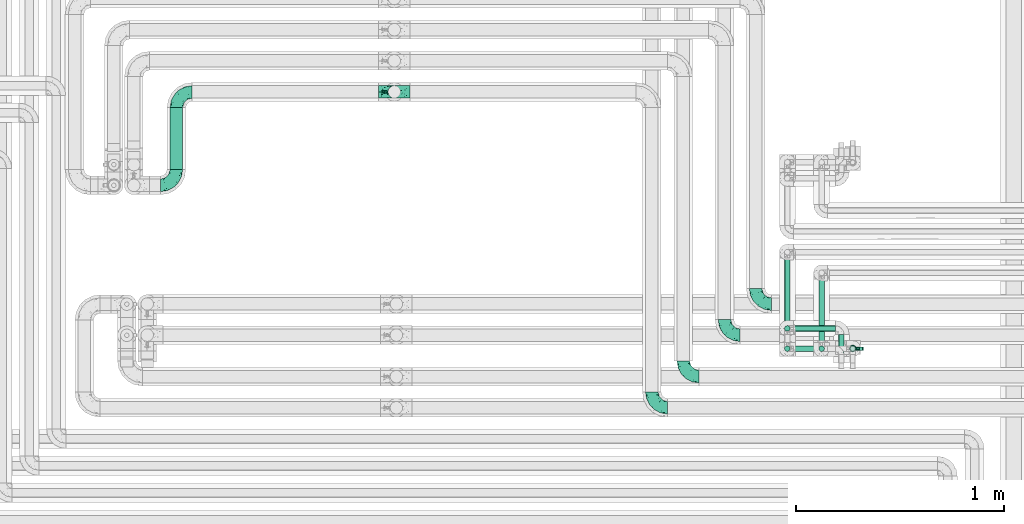
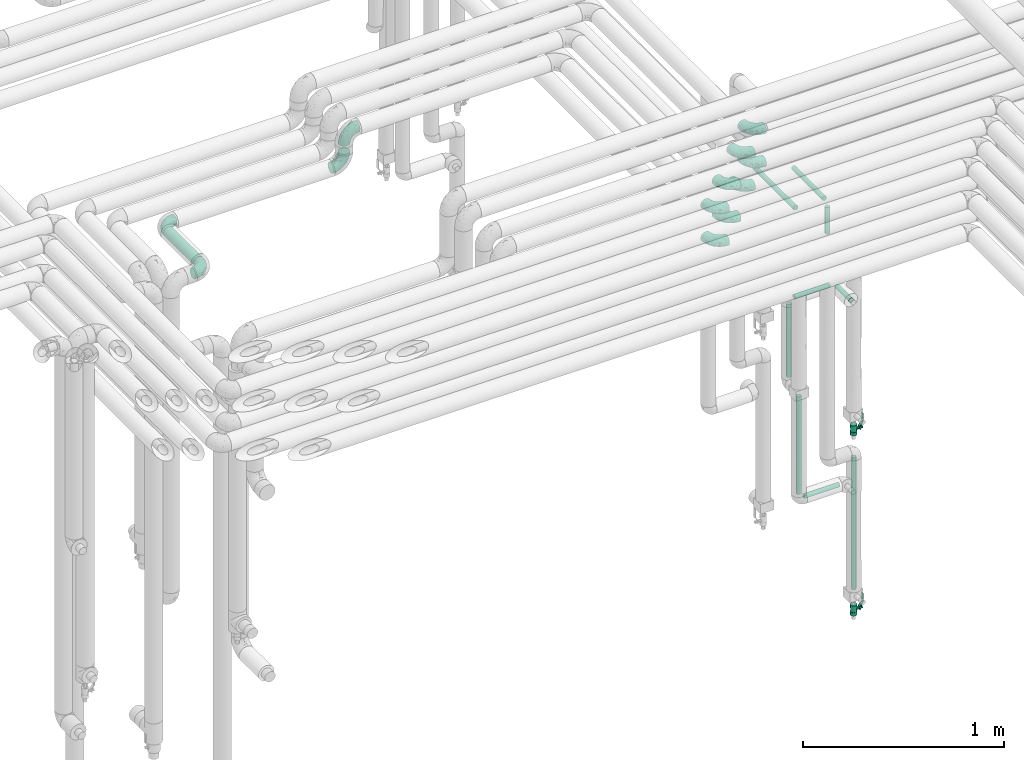
# One storey, part 634 of 824: 12 flow fittings, 10 flow segments, 2 flow controllers.
"""IFC2X3 building model written with IfcOpenShell, lengths in millimetres."""

from ifc_helpers import new_model, entity, si_unit, converted_unit, derived_unit, direction, frame, origin, origin_2d_with_axis, place, context, subcontext, project, spatial, polyline, circle, outline, extrude, faceted_brep, source, transform, mapped, material, material_list, type_object, type_shapes, element, save


model = new_model("IFC2X3")

# Units and contexts
model_context = context("Model", 3, precision=0.01, world=origin(), true_north=direction((6.12303176911189e-17, 1.0)))
body_context = subcontext(model_context, "Body", "Model", "MODEL_VIEW")
ifc_project = project(units=[si_unit("LENGTHUNIT", "METRE", prefix="MILLI"), si_unit("AREAUNIT", "SQUARE_METRE"), si_unit("VOLUMEUNIT", "CUBIC_METRE"), converted_unit("PLANEANGLEUNIT", "DEGREE", entity("IfcRatioMeasure", 0.0174532925199433), si_unit("PLANEANGLEUNIT", "RADIAN"), dimensions=[0, 0, 0, 0, 0, 0, 0]), si_unit("MASSUNIT", "GRAM", prefix="KILO"), derived_unit("MASSDENSITYUNIT", [(si_unit("MASSUNIT", "GRAM", prefix="KILO"), 1), (si_unit("LENGTHUNIT", "METRE"), -3)]), derived_unit("MOMENTOFINERTIAUNIT", [(si_unit("LENGTHUNIT", "METRE"), 4)]), si_unit("TIMEUNIT", "SECOND"), si_unit("FREQUENCYUNIT", "HERTZ"), si_unit("THERMODYNAMICTEMPERATUREUNIT", "DEGREE_CELSIUS"), derived_unit("THERMALTRANSMITTANCEUNIT", [(si_unit("MASSUNIT", "GRAM", prefix="KILO"), 1), (si_unit("THERMODYNAMICTEMPERATUREUNIT", "KELVIN"), -1), (si_unit("TIMEUNIT", "SECOND"), -3)]), derived_unit("VOLUMETRICFLOWRATEUNIT", [(si_unit("LENGTHUNIT", "METRE"), 3), (si_unit("TIMEUNIT", "SECOND"), -1)]), derived_unit("MASSFLOWRATEUNIT", [(si_unit("MASSUNIT", "GRAM", prefix="KILO"), 1), (si_unit("TIMEUNIT", "SECOND"), -1)]), derived_unit("ROTATIONALFREQUENCYUNIT", [(si_unit("TIMEUNIT", "SECOND"), -1)]), si_unit("ELECTRICCURRENTUNIT", "AMPERE"), si_unit("ELECTRICVOLTAGEUNIT", "VOLT"), si_unit("POWERUNIT", "WATT"), si_unit("FORCEUNIT", "NEWTON", prefix="KILO"), si_unit("ILLUMINANCEUNIT", "LUX"), si_unit("LUMINOUSFLUXUNIT", "LUMEN"), si_unit("LUMINOUSINTENSITYUNIT", "CANDELA"), derived_unit("USERDEFINED", [(si_unit("MASSUNIT", "GRAM", prefix="KILO"), -1), (si_unit("LENGTHUNIT", "METRE"), -2), (si_unit("TIMEUNIT", "SECOND"), 3), (si_unit("LUMINOUSFLUXUNIT", "LUMEN"), 1)]), derived_unit("LINEARVELOCITYUNIT", [(si_unit("LENGTHUNIT", "METRE"), 1), (si_unit("TIMEUNIT", "SECOND"), -1)]), si_unit("PRESSUREUNIT", "PASCAL"), derived_unit("USERDEFINED", [(si_unit("LENGTHUNIT", "METRE"), -2), (si_unit("MASSUNIT", "GRAM", prefix="KILO"), 1), (si_unit("TIMEUNIT", "SECOND"), -2)]), derived_unit("LINEARFORCEUNIT", [(si_unit("MASSUNIT", "GRAM", prefix="KILO"), 1), (si_unit("LENGTHUNIT", "METRE"), 1), (si_unit("TIMEUNIT", "SECOND"), -2), (si_unit("LENGTHUNIT", "METRE"), -1)]), derived_unit("PLANARFORCEUNIT", [(si_unit("MASSUNIT", "GRAM", prefix="KILO"), 1), (si_unit("LENGTHUNIT", "METRE"), 1), (si_unit("TIMEUNIT", "SECOND"), -2), (si_unit("LENGTHUNIT", "METRE"), -2)])], contexts=[model_context])

# Site, building, storey
site_placement = place(None, origin())
site = spatial("IfcSite", under=ifc_project, at=site_placement, CompositionType="ELEMENT")
building_placement = place(site_placement, origin())
building = spatial("IfcBuilding", under=site, at=building_placement, CompositionType="ELEMENT")
storey_placement = place(building_placement, frame((0.0, 0.0, 28200.0)))
storey = spatial("IfcBuildingStorey", under=building, at=storey_placement, CompositionType="ELEMENT", Elevation=28200.0)

# Flow segments
pipe_segment_type = type_object("IfcPipeSegmentType", PredefinedType="NOTDEFINED")
flow_segment_1_placement = place(storey_placement, frame((31853.66, 15787.2, 2968.4)))
element("IfcFlowSegment", 1, at=flow_segment_1_placement, inside=storey, type_object=pipe_segment_type, context=body_context, shape_type="SweptSolid", body=[
    extrude(circle(Radius=30.0, at=origin_2d_with_axis()), frame((31.6, 0.0, 31.6), z_axis=(0.0, 1.0, 0.0), x_axis=(-1.0, 0.0, 0.0)), (0.0, 0.0, 1.0), 298.000000000006),
])
flow_segment_2_placement = place(storey_placement, frame((34812.85, 14909.92, 1089.1)))
element("IfcFlowSegment", 2, at=flow_segment_2_placement, inside=storey, type_object=pipe_segment_type, context=body_context, shape_type="SweptSolid", body=[
    extrude(circle(Radius=13.4, at=origin_2d_with_axis()), frame((15.0, 15.0, 0.0)), (0.0, 0.0, 1.0), 591.900000000008),
])
flow_segment_3_placement = place(storey_placement, frame((34856.95, 14909.92, 1045.0)))
element("IfcFlowSegment", 3, at=flow_segment_3_placement, inside=storey, type_object=pipe_segment_type, context=body_context, shape_type="SweptSolid", body=[
    extrude(circle(Radius=13.4, at=origin_2d_with_axis()), frame((0.0, 15.0, 15.0), z_axis=(1.0, 0.0, 0.0), x_axis=(0.0, -1.0, 0.0)), (0.0, 0.0, 1.0), 201.799999999997),
])
flow_segment_4_placement = place(storey_placement, frame((34856.95, 15006.91, 2195.0)))
element("IfcFlowSegment", 4, at=flow_segment_4_placement, inside=storey, type_object=pipe_segment_type, context=body_context, shape_type="SweptSolid", body=[
    extrude(circle(Radius=13.4, at=origin_2d_with_axis()), frame((0.0, 15.0, 15.0), z_axis=(1.0, 0.0, 0.0), x_axis=(0.0, 1.0, 0.0)), (0.0, 0.0, 1.0), 201.799999999997),
])
flow_segment_5_placement = place(storey_placement, frame((35072.85, 14854.91, 2195.0)))
element("IfcFlowSegment", 5, at=flow_segment_5_placement, inside=storey, type_object=pipe_segment_type, context=body_context, shape_type="SweptSolid", body=[
    extrude(circle(Radius=13.4, at=origin_2d_with_axis()), frame((15.0, 0.0, 15.0), z_axis=(0.0, 1.0, 0.0), x_axis=(1.0, 0.0, 0.0)), (0.0, 0.0, 1.0), 137.895089895177),
])
flow_segment_6_placement = place(storey_placement, frame((34812.85, 15006.91, 1739.1)))
element("IfcFlowSegment", 6, at=flow_segment_6_placement, inside=storey, type_object=pipe_segment_type, context=body_context, shape_type="SweptSolid", body=[
    extrude(circle(Radius=13.4, at=origin_2d_with_axis()), frame((15.0, 15.0, 0.0)), (0.0, 0.0, 1.0), 441.800000000021),
])
flow_segment_7_placement = place(storey_placement, frame((35127.89, 14909.92, 401.0)))
element("IfcFlowSegment", 7, at=flow_segment_7_placement, inside=storey, type_object=pipe_segment_type, context=body_context, shape_type="SweptSolid", body=[
    extrude(circle(Radius=13.4, at=origin_2d_with_axis()), frame((15.0, 15.0, 0.0)), (0.0, 0.0, 1.0), 799.899999999658),
])
flow_segment_8_placement = place(storey_placement, frame((34977.89, 14909.92, 2609.0)))
element("IfcFlowSegment", 8, at=flow_segment_8_placement, inside=storey, type_object=pipe_segment_type, context=body_context, shape_type="SweptSolid", body=[
    extrude(circle(Radius=13.4, at=origin_2d_with_axis()), frame((15.0, 15.0, 0.0), z_axis=(0.0, 0.0, 1.0), x_axis=(-1.0, 0.0, 0.0)), (0.0, 0.0, 1.0), 161.899999999968),
])
flow_segment_9_placement = place(storey_placement, frame((34977.89, 14954.01, 2785.0)))
element("IfcFlowSegment", 9, at=flow_segment_9_placement, inside=storey, type_object=pipe_segment_type, context=body_context, shape_type="SweptSolid", body=[
    extrude(circle(Radius=13.4, at=origin_2d_with_axis()), frame((15.0, 0.0, 15.0), z_axis=(0.0, 1.0, 0.0), x_axis=(-1.0, 0.0, 0.0)), (0.0, 0.0, 1.0), 306.888117846957),
])
flow_segment_10_placement = place(storey_placement, frame((34812.85, 14954.01, 2785.0)))
element("IfcFlowSegment", 10, at=flow_segment_10_placement, inside=storey, type_object=pipe_segment_type, context=body_context, shape_type="SweptSolid", body=[
    extrude(circle(Radius=13.4, at=origin_2d_with_axis()), frame((15.0, 0.0, 15.0), z_axis=(0.0, 1.0, 0.0), x_axis=(1.0, 0.0, 0.0)), (0.0, 0.0, 1.0), 406.488125846979),
])

# Flow controllers
ifc_material = material()
ifc_material_list = material_list([ifc_material, ifc_material, ifc_material, ifc_material, ifc_material])
valve_type = type_object("IfcValveType", PredefinedType="NOTDEFINED", material=ifc_material_list)
shared_shape_1 = source(origin(), body_context, "Body", "SweptSolid", [
    extrude(circle(Radius=17.5, at=origin_2d_with_axis()), frame((-30.5, 0.0, 0.0), z_axis=(1.0, 0.0, 0.0), x_axis=(0.0, 1.0, 0.0)), (0.0, 0.0, 1.0), 20.3333333333333),
    extrude(circle(Radius=16.0, at=origin_2d_with_axis()), frame((-10.17, 0.0, 0.0), z_axis=(1.0, 0.0, 0.0), x_axis=(0.0, 1.0, 0.0)), (0.0, 0.0, 1.0), 20.3333333333333),
    extrude(circle(Radius=17.5, at=origin_2d_with_axis()), frame((10.17, 0.0, 0.0), z_axis=(1.0, 0.0, 0.0), x_axis=(0.0, 1.0, 0.0)), (0.0, 0.0, 1.0), 20.3333333333333),
    extrude(outline(polyline([(-38.75, -5.0), (-38.75, -10.0), (-17.92, -10.0), (2.08, 5.0), (56.25, 5.0), (56.25, 10.0), (0.42, 10.0), (-19.58, -5.0), (-38.75, -5.0)])), frame((28.75, -8.75, 41.5), z_axis=(0.0, -1.0, 0.0), x_axis=(1.0, 0.0, 0.0)), (0.0, 0.0, -1.0), 17.5),
    extrude(circle(Radius=8.0, at=origin_2d_with_axis()), origin(), (0.0, 0.0, 1.0), 49.0),
])
type_shapes(valve_type, [shared_shape_1])
for number, where, z_axis, x_axis in (
    (11, (35142.88, 14924.91, 274.5), (1.0, 0.0, 0.0), (0.0, 0.0, 1.0)),
    (12, (35142.88, 14924.91, 1366.0), (1.0, 0.0, 0.0), (0.0, 0.0, 1.0)),
):
    element("IfcFlowController", number, at=place(storey_placement, frame(where, z_axis=z_axis, x_axis=x_axis)), inside=storey, type_object=valve_type, material=ifc_material, context=body_context, shape_type="MappedRepresentation", body=[
        mapped(shared_shape_1, transform((0.0, 0.0, 0.0), scale=1.0)),
    ])

# Flow fittings
pipe_fitting_type = type_object("IfcPipeFittingType", PredefinedType="NOTDEFINED", material=ifc_material)
shared_shape_2 = source(origin(), body_context, "Body", "Brep", [
    faceted_brep([(-76.0, 15.07, -26.11), (-76.0, 7.8, -29.12), (-76.0, 0.0, -30.15), (-76.0, -7.8, -29.12), (-76.0, -15.08, -26.11), (-76.0, -21.32, -21.32), (-76.0, -26.11, -15.08), (-76.0, -29.12, -7.8), (-76.0, -30.15, 0.0), (-76.0, -29.12, 7.8), (-76.0, -26.11, 15.07), (-76.0, -21.32, 21.32), (-76.0, -15.08, 26.11), (-76.0, -7.8, 29.12), (-76.0, 0.0, 30.15), (-76.0, 7.8, 29.12), (-76.0, 15.07, 26.11), (-76.0, 21.32, 21.32), (-76.0, 26.11, 15.07), (-76.0, 29.12, 7.8), (-76.0, 30.15, 0.0), (-76.0, 29.12, -7.8), (-76.0, 26.11, -15.08), (-76.0, 21.32, -21.32), (0.0, 76.0, -30.15), (-7.8, 76.0, -29.12), (-15.07, 76.0, -26.11), (-21.32, 76.0, -21.32), (-26.11, 76.0, -15.08), (-29.12, 76.0, -7.8), (-30.15, 76.0, 0.0), (-29.12, 76.0, 7.8), (-26.11, 76.0, 15.07), (-21.32, 76.0, 21.32), (-15.07, 76.0, 26.11), (-7.8, 76.0, 29.12), (0.0, 76.0, 30.15), (7.8, 76.0, 29.12), (15.08, 76.0, 26.11), (21.32, 76.0, 21.32), (26.11, 76.0, 15.07), (29.12, 76.0, 7.8), (30.15, 76.0, 0.0), (29.12, 76.0, -7.8), (26.11, 76.0, -15.08), (21.32, 76.0, -21.32), (15.08, 76.0, -26.11), (7.8, 76.0, -29.12), (10.79, 31.43, 21.07), (4.32, 31.7, 25.72), (1.65, 15.19, 19.92), (-61.17, -27.8, 0.0), (-51.1, -25.49, 9.84), (-56.14, -10.61, 27.27), (-31.7, -4.32, 25.72), (-39.75, 1.72, 29.41), (-43.2, -24.95, 0.0), (-1.86, 1.86, 0.0), (4.49, 7.65, 5.78), (-7.82, -4.61, 5.83), (-56.21, -22.79, 17.21), (-58.98, -3.38, 29.7), (-53.96, 5.6, 30.07), (-10.86, 10.86, 25.48), (-17.2, -2.6, 20.44), (-49.15, -16.01, 22.7), (-22.18, -14.24, 7.99), (-28.4, -17.42, 0.0), (-13.61, -9.88, 0.0), (-39.0, 23.48, 27.76), (-58.76, 12.54, 28.36), (-41.61, 15.41, 29.48), (16.01, 49.15, 22.7), (-58.55, 25.93, 19.53), (-51.53, 33.5, 13.51), (-64.92, 28.76, 12.4), (-7.48, 23.14, 28.25), (-1.72, 39.75, 29.41), (-12.04, 27.88, 29.88), (-63.91, 18.81, 24.52), (-11.63, 65.16, 28.18), (-4.97, 57.02, 30.05), (9.88, 13.61, 0.0), (-62.5, 31.74, 5.02), (-45.17, 30.98, 21.2), (-21.78, 9.76, 28.58), (10.61, 56.14, 27.27), (-32.09, 54.42, 13.26), (22.79, 56.21, 17.21), (15.38, 31.17, 15.63), (25.49, 51.1, 9.84), (21.84, 36.35, 5.92), (24.95, 43.2, 0.0), (3.38, 58.98, 29.7), (-31.17, -15.38, 15.63), (-39.39, 41.78, 15.45), (-34.56, 41.13, 20.79), (-39.81, -23.25, 5.49), (27.8, 61.17, 0.0), (-31.74, 62.5, 5.02), (-53.07, 36.29, 0.0), (-42.95, 42.95, 7.29), (-36.29, 53.07, 0.0), (-19.83, 58.51, 24.79), (-25.48, 60.2, 19.41), (-14.53, 50.96, 28.57), (-13.31, 37.09, 30.07), (-26.16, 40.06, 26.4), (-32.43, -10.35, 21.9), (17.42, 28.4, 0.0), (14.24, 22.18, 7.99), (-38.67, 9.72, 30.15), (-24.66, 17.36, 30.09), (-37.08, 31.49, 24.99), (-49.27, 22.83, 25.24), (-20.8, 38.81, 28.63), (-27.58, 27.58, 29.2), (-36.07, -20.23, 10.71), (-15.19, -6.16, 14.9), (6.6, 15.4, 14.49), (-2.51, 2.51, 11.35), (-65.16, 11.63, -28.18), (-49.15, -16.01, -22.7), (-57.02, 4.97, -30.05), (-25.93, 58.55, -19.53), (-33.5, 51.53, -13.51), (-28.76, 64.92, -12.4), (-60.2, 25.48, -19.41), (-58.51, 19.83, -24.79), (4.61, 7.82, -5.83), (-7.65, -4.49, -5.78), (-2.51, 2.51, -11.35), (-62.5, 31.74, -5.02), (-50.96, 14.53, -28.57), (-37.09, 13.31, -30.07), (-42.95, 42.95, -7.29), (25.49, 51.1, -9.84), (22.79, 56.21, -17.21), (-40.06, 26.16, -26.4), (3.38, 58.98, -29.7), (-5.6, 53.96, -30.07), (-27.88, 12.04, -29.88), (-9.76, 21.78, -28.58), (-23.14, 7.48, -28.25), (-51.1, -25.49, -9.84), (15.38, 31.17, -15.63), (16.01, 49.15, -22.7), (-23.48, 39.0, -27.76), (-12.54, 58.76, -28.36), (-15.41, 41.61, -29.48), (-56.21, -22.79, -17.21), (-9.72, 38.67, -30.15), (-17.36, 24.66, -30.09), (-22.18, -14.24, -7.99), (-41.13, 34.56, -20.79), (-31.74, 62.5, -5.02), (-58.98, -3.38, -29.7), (-31.17, -15.38, -15.63), (-56.14, -10.61, -27.27), (14.24, 22.18, -7.99), (23.25, 39.81, -5.49), (-31.49, 37.08, -24.99), (-15.19, -6.16, -14.9), (1.65, 15.19, -19.92), (-18.81, 63.91, -24.52), (-32.59, -11.62, -20.84), (-31.7, -4.32, -25.72), (-17.2, -2.6, -20.44), (-39.75, 1.72, -29.41), (-54.42, 32.09, -13.26), (-30.98, 45.17, -21.2), (10.61, 56.14, -27.27), (10.23, 31.31, -21.52), (4.32, 31.7, -25.72), (-41.78, 39.39, -15.45), (-1.72, 39.75, -29.41), (-36.35, -21.84, -5.92), (-22.83, 49.27, -25.24), (-38.81, 20.8, -28.63), (-27.58, 27.58, -29.2), (-10.86, 10.86, -25.48), (20.23, 36.07, -10.71), (6.6, 15.4, -14.49)], [[[0, 1, 2, 3, 4, 5, 6, 7, 8, 9, 10, 11, 12, 13, 14, 15, 16, 17, 18, 19, 20, 21, 22, 23]], [[24, 25, 26, 27, 28, 29, 30, 31, 32, 33, 34, 35, 36, 37, 38, 39, 40, 41, 42, 43, 44, 45, 46, 47]], [[48, 49, 50]], [[51, 52, 9]], [[53, 54, 55]], [[9, 52, 10]], [[56, 52, 51]], [[57, 58, 59]], [[11, 10, 60]], [[14, 61, 62]], [[63, 54, 64]], [[65, 12, 11]], [[65, 53, 12]], [[66, 67, 68]], [[69, 70, 71]], [[72, 39, 38]], [[73, 74, 75]], [[15, 70, 16]], [[76, 77, 78]], [[16, 79, 17]], [[13, 61, 14]], [[35, 80, 81]], [[14, 62, 15]], [[17, 73, 18]], [[57, 82, 58]], [[20, 19, 83]], [[75, 19, 18]], [[70, 15, 62]], [[73, 84, 74]], [[78, 85, 76]], [[38, 86, 72]], [[32, 31, 87]], [[88, 89, 90]], [[91, 92, 90]], [[72, 86, 49]], [[36, 93, 37]], [[75, 83, 19]], [[36, 35, 81]], [[60, 94, 65]], [[40, 90, 41]], [[95, 96, 87]], [[88, 90, 40]], [[66, 97, 67]], [[90, 98, 41]], [[40, 39, 88]], [[99, 31, 30]], [[20, 83, 100]], [[101, 102, 100]], [[52, 60, 10]], [[102, 99, 30]], [[96, 103, 104]], [[83, 101, 100]], [[12, 53, 13]], [[104, 103, 33]], [[105, 106, 81]], [[107, 105, 103]], [[64, 54, 108]], [[80, 103, 105]], [[80, 35, 34]], [[34, 33, 103]], [[86, 38, 37]], [[109, 110, 82]], [[71, 111, 112]], [[69, 107, 113]], [[79, 73, 17]], [[114, 113, 84]], [[33, 32, 104]], [[115, 107, 116]], [[105, 115, 106]], [[93, 81, 77]], [[54, 53, 65]], [[61, 53, 55]], [[108, 94, 64]], [[54, 63, 85]], [[93, 86, 37]], [[77, 76, 49]], [[77, 49, 86]], [[49, 63, 50]], [[60, 52, 117]], [[65, 11, 60]], [[39, 72, 88]], [[89, 88, 72]], [[71, 70, 62]], [[79, 70, 114]], [[103, 96, 107]], [[69, 113, 114]], [[112, 106, 116]], [[77, 81, 106]], [[112, 116, 71]], [[112, 55, 85]], [[64, 50, 63]], [[57, 59, 68]], [[32, 87, 104]], [[96, 104, 87]], [[94, 118, 64]], [[50, 119, 89]], [[50, 64, 118]], [[50, 89, 48]], [[81, 93, 36]], [[86, 93, 77]], [[53, 61, 13]], [[62, 61, 55]], [[71, 62, 111]], [[69, 71, 116]], [[95, 101, 74]], [[99, 101, 87]], [[118, 66, 59]], [[117, 97, 66]], [[117, 66, 94]], [[91, 89, 110]], [[91, 110, 109]], [[110, 89, 119]], [[9, 8, 51]], [[98, 90, 92]], [[98, 42, 41]], [[101, 83, 74]], [[101, 99, 102]], [[87, 31, 99]], [[62, 55, 111]], [[55, 112, 111]], [[107, 69, 116]], [[70, 69, 114]], [[107, 96, 113]], [[84, 113, 96]], [[84, 96, 95]], [[114, 84, 73]], [[70, 79, 16]], [[73, 79, 114]], [[54, 85, 55]], [[76, 85, 63]], [[49, 76, 63]], [[77, 106, 78]], [[106, 112, 78]], [[85, 78, 112]], [[73, 75, 18]], [[83, 75, 74]], [[103, 80, 34]], [[81, 80, 105]], [[101, 95, 87]], [[84, 95, 74]], [[106, 115, 116]], [[105, 107, 115]], [[120, 59, 58]], [[82, 110, 58]], [[119, 58, 110]], [[118, 59, 120]], [[66, 68, 59]], [[54, 65, 108]], [[94, 108, 65]], [[66, 118, 94]], [[50, 118, 120]], [[50, 120, 119]], [[119, 120, 58]], [[89, 72, 48]], [[49, 48, 72]], [[60, 117, 94]], [[117, 52, 97]], [[52, 56, 97]], [[67, 97, 56]], [[92, 91, 109]], [[89, 91, 90]], [[121, 1, 0]], [[122, 5, 4]], [[2, 1, 123]], [[124, 125, 126]], [[127, 128, 23]], [[129, 130, 131]], [[100, 132, 20]], [[133, 134, 123]], [[135, 100, 102]], [[136, 137, 44]], [[133, 128, 138]], [[24, 139, 140]], [[141, 142, 143]], [[121, 128, 133]], [[6, 144, 7]], [[137, 145, 146]], [[144, 51, 7]], [[147, 148, 149]], [[144, 6, 150]], [[149, 151, 152]], [[153, 68, 67]], [[154, 128, 127]], [[30, 155, 102]], [[43, 42, 98]], [[156, 3, 2]], [[157, 144, 150]], [[158, 4, 3]], [[24, 140, 25]], [[155, 135, 102]], [[159, 160, 109]], [[30, 29, 155]], [[147, 138, 161]], [[27, 124, 28]], [[57, 129, 82]], [[162, 163, 131]], [[27, 26, 164]], [[148, 26, 25]], [[165, 166, 167]], [[24, 47, 139]], [[143, 168, 141]], [[22, 21, 169]], [[125, 124, 170]], [[148, 25, 140]], [[46, 146, 171]], [[158, 122, 4]], [[0, 23, 128]], [[1, 121, 123]], [[109, 82, 159]], [[45, 44, 137]], [[146, 46, 45]], [[136, 43, 98]], [[132, 21, 20]], [[136, 98, 92]], [[172, 173, 146]], [[46, 171, 47]], [[43, 136, 44]], [[174, 154, 169]], [[171, 173, 175]], [[6, 5, 150]], [[126, 29, 28]], [[176, 56, 144]], [[122, 158, 166]], [[164, 124, 27]], [[177, 161, 170]], [[23, 22, 127]], [[178, 138, 179]], [[133, 178, 134]], [[156, 123, 168]], [[156, 158, 3]], [[168, 143, 166]], [[168, 166, 158]], [[166, 180, 167]], [[173, 171, 146]], [[139, 171, 175]], [[172, 145, 163]], [[173, 180, 142]], [[5, 122, 150]], [[157, 150, 122]], [[137, 136, 181]], [[146, 45, 137]], [[149, 148, 140]], [[164, 148, 177]], [[128, 154, 138]], [[147, 161, 177]], [[152, 134, 179]], [[168, 123, 134]], [[152, 179, 149]], [[152, 175, 142]], [[57, 130, 129]], [[157, 165, 167]], [[22, 169, 127]], [[154, 127, 169]], [[163, 167, 180]], [[162, 157, 167]], [[173, 163, 180]], [[182, 163, 145]], [[123, 156, 2]], [[158, 156, 168]], [[171, 139, 47]], [[140, 139, 175]], [[149, 140, 151]], [[147, 149, 179]], [[174, 135, 125]], [[132, 135, 169]], [[176, 157, 153]], [[176, 153, 67]], [[153, 157, 162]], [[182, 159, 129]], [[181, 160, 159]], [[181, 159, 145]], [[51, 144, 56]], [[51, 8, 7]], [[135, 132, 100]], [[169, 21, 132]], [[126, 155, 29]], [[135, 155, 125]], [[140, 175, 151]], [[175, 152, 151]], [[138, 147, 179]], [[148, 147, 177]], [[138, 154, 161]], [[170, 161, 154]], [[170, 154, 174]], [[177, 170, 124]], [[148, 164, 26]], [[124, 164, 177]], [[173, 142, 175]], [[143, 142, 180]], [[166, 143, 180]], [[168, 134, 141]], [[134, 152, 141]], [[142, 141, 152]], [[124, 126, 28]], [[155, 126, 125]], [[128, 121, 0]], [[123, 121, 133]], [[135, 174, 169]], [[170, 174, 125]], [[134, 178, 179]], [[133, 138, 178]], [[130, 153, 162]], [[68, 153, 130]], [[57, 68, 130]], [[182, 129, 131]], [[159, 82, 129]], [[157, 122, 165]], [[166, 165, 122]], [[163, 162, 167]], [[162, 131, 130]], [[145, 172, 146]], [[163, 173, 172]], [[159, 182, 145]], [[131, 163, 182]], [[56, 176, 67]], [[157, 176, 144]], [[137, 181, 145]], [[181, 136, 160]], [[136, 92, 160]], [[109, 160, 92]]]),
])
type_shapes(pipe_fitting_type, [shared_shape_2])
for number, where, z_axis, x_axis in (
    (13, (34675.03, 15139.0, 3000.0), (0.0, 0.0, 1.0), (0.0, -1.0, 0.0)),
    (14, (34525.03, 14989.0, 3000.0), (0.0, 0.0, 1.0), (0.0, -1.0, 0.0)),
    (15, (34326.66, 14790.0, 3000.0), (0.0, 0.0, 1.0), (0.0, -1.0, 0.0)),
    (16, (34675.03, 15139.0, 3200.0), (0.0, 0.0, 1.0), (0.0, -1.0, 0.0)),
    (17, (34326.66, 14790.0, 3200.0), (0.0, 0.0, 1.0), (0.0, -1.0, 0.0)),
    (18, (32935.03, 16161.2, 3200.0), (0.0, -1.0, 0.0), (-1.0, 0.0, 0.0)),
    (19, (32935.03, 16161.2, 3000.0), (0.0, 1.0, 0.0), (0.0, 0.0, -1.0)),
    (20, (31885.25, 16161.2, 3000.0), (0.0, 0.0, 1.0), (-1.0, 0.0, 0.0)),
):
    element("IfcFlowFitting", number, at=place(storey_placement, frame(where, z_axis=z_axis, x_axis=x_axis)), inside=storey, type_object=pipe_fitting_type, material=ifc_material, context=body_context, shape_type="MappedRepresentation", body=[
        mapped(shared_shape_2, transform((0.0, 0.0, 0.0), scale=1.0)),
    ])
flow_fitting_placement = place(storey_placement, frame((31885.25, 15711.2, 3000.0)))
element("IfcFlowFitting", 21, at=flow_fitting_placement, inside=storey, type_object=pipe_fitting_type, material=ifc_material, context=body_context, shape_type="MappedRepresentation", body=[
    mapped(shared_shape_2, transform((0.0, 0.0, 0.0), scale=1.0)),
])
for number, where, z_axis, x_axis in (
    (22, (34175.03, 14640.0, 3000.0), (0.0, 0.0, 1.0), (0.0, -1.0, 0.0)),
    (23, (34525.03, 14989.0, 3200.0), (0.0, 0.0, 1.0), (0.0, -1.0, 0.0)),
    (24, (34175.03, 14640.0, 3200.0), (0.0, 0.0, 1.0), (0.0, -1.0, 0.0)),
):
    element("IfcFlowFitting", number, at=place(storey_placement, frame(where, z_axis=z_axis, x_axis=x_axis)), inside=storey, type_object=pipe_fitting_type, material=ifc_material, context=body_context, shape_type="MappedRepresentation", body=[
        mapped(shared_shape_2, transform((0.0, 0.0, 0.0), scale=1.0)),
    ])

save(model, "model.ifc")
